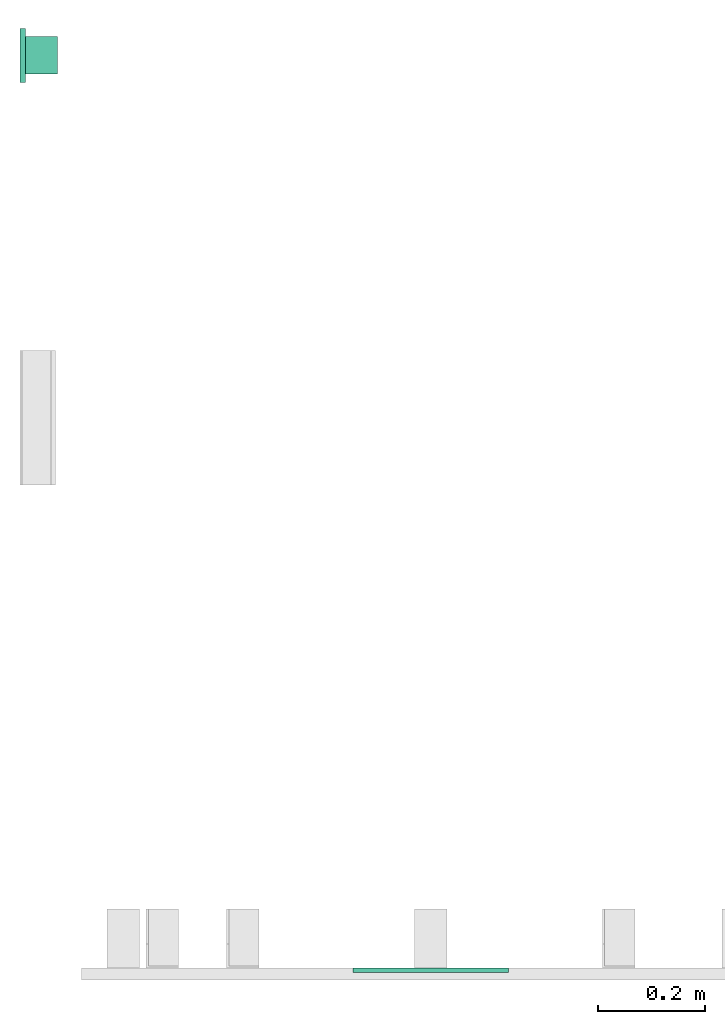
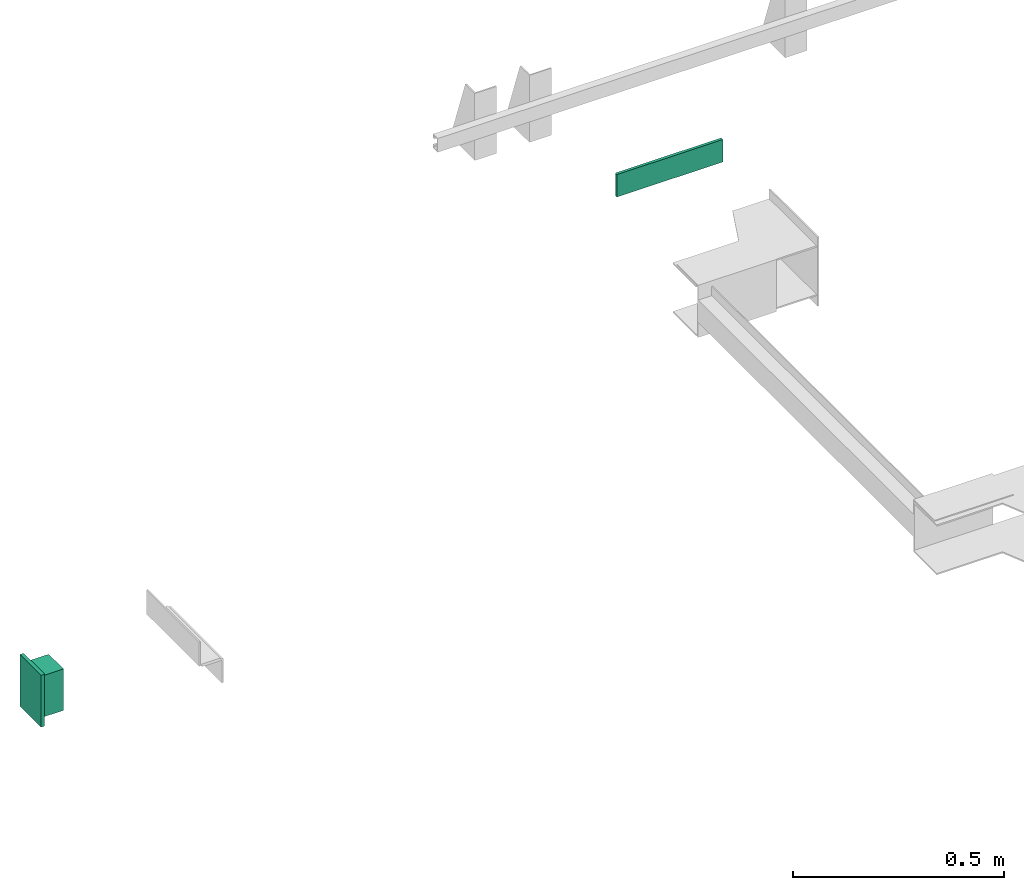
# One storey, part 3 of 4: 1 lamp, 1 switching device.
"""IFC4 building model written with IfcOpenShell, lengths in millimetres."""

from ifc_helpers import new_model, entity, si_unit, converted_unit, frame, origin_with_axes, place, context, subcontext, project, spatial, faceted_brep, element, save


model = new_model("IFC4")

# Units and contexts
context_of_model = context(None, 3, precision=0.01, world=origin_with_axes())
sub_context_1 = subcontext(context_of_model, None, None, "MODEL_VIEW")
sub_context_2 = subcontext(context_of_model, None, None, "MODEL_VIEW")
ifc_project = project(units=[converted_unit("PLANEANGLEUNIT", "degree", entity("IfcPlaneAngleMeasure", 0.017453292519943), si_unit("PLANEANGLEUNIT", "RADIAN"), dimensions=[0, 0, 0, 0, 0, 0, 0]), si_unit("LENGTHUNIT", "METRE", prefix="MILLI"), si_unit("MASSUNIT", "GRAM", prefix="KILO"), converted_unit("TIMEUNIT", "year", entity("IfcTimeMeasure", 31557600.0), si_unit("TIMEUNIT", "SECOND"), dimensions=[0, 0, 1, 0, 0, 0, 0]), si_unit("THERMODYNAMICTEMPERATUREUNIT", "DEGREE_CELSIUS"), si_unit("AREAUNIT", "SQUARE_METRE"), si_unit("FORCEUNIT", "NEWTON"), si_unit("VOLUMEUNIT", "CUBIC_METRE"), si_unit("PRESSUREUNIT", "PASCAL"), si_unit("SOLIDANGLEUNIT", "STERADIAN")], contexts=[context_of_model])

# Site, building, storey
site = spatial("IfcSite", under=ifc_project)
building = spatial("IfcBuilding", under=site, Name="Document")
placement = place(None, origin_with_axes())
storey_placement = place(placement, frame((0.0, 0.0, -23290.0), z_axis=(0.0, 0.0, 1.0), x_axis=(1.0, 0.0, 0.0)))
storey = spatial("IfcBuildingStorey", under=building, at=storey_placement, Name="P10", Elevation=-23290.0)

# Switching device
switching_device_placement = place(storey_placement, frame((765.0, 0.0, 2280.0), z_axis=(0.0, 0.0, 1.0), x_axis=(1.0, 0.0, 0.0)))
element("IfcSwitchingDevice", 1, at=switching_device_placement, inside=storey, context=sub_context_1, shape_type="Brep", body=[
    faceted_brep([(-145.0, -8.0, 32.5), (145.0, -8.0, 32.5), (145.0, 0.0, 32.5), (-145.0, 0.0, 32.5), (-145.0, -8.0, -32.5), (-145.0, 0.0, -32.5), (145.0, 0.0, -32.5), (145.0, -8.0, -32.5)], [[[0, 1, 2, 3]], [[4, 5, 6, 7]], [[0, 3, 5, 4]], [[3, 2, 6, 5]], [[2, 1, 7, 6]], [[1, 0, 4, 7]]]),
])

# Lamp
lamp_placement = place(storey_placement, frame((0.0, 1700.0, -0.769230769230944), z_axis=(0.0, 0.0, 1.0), x_axis=(0.0, -1.0, 0.0)))
element("IfcLamp", 2, at=lamp_placement, inside=storey, ObjectType="Lamp S5500", context=sub_context_2, shape_type="Brep", body=[
    faceted_brep([(35.0, 10.0, 59.999943659855944), (35.0, 70.0, 59.999943659855944), (-35.0, 70.0, 59.999943659855944), (-35.0, 10.0, 59.999943659855944), (35.0, 10.0, -60.000056340144056), (-35.0, 10.0, -60.000056340144056), (-35.0, 70.0, -60.000056340144056), (35.0, 70.0, -60.000056340144056)], [[[0, 1, 2, 3]], [[4, 5, 6, 7]], [[0, 3, 5, 4]], [[3, 2, 6, 5]], [[2, 1, 7, 6]], [[1, 0, 4, 7]]]),
    faceted_brep([(50.0, 0.0, 74.99994365985594), (50.0, 10.0, 74.99994365985594), (-50.0, 10.0, 74.99994365985594), (-50.0, 0.0, 74.99994365985594), (50.0, 0.0, -75.00005634014406), (-50.0, 0.0, -75.00005634014406), (-50.0, 10.0, -75.00005634014406), (50.0, 10.0, -75.00005634014406)], [[[0, 1, 2, 3]], [[4, 5, 6, 7]], [[0, 3, 5, 4]], [[3, 2, 6, 5]], [[2, 1, 7, 6]], [[1, 0, 4, 7]]]),
])

save(model, "model.ifc")
